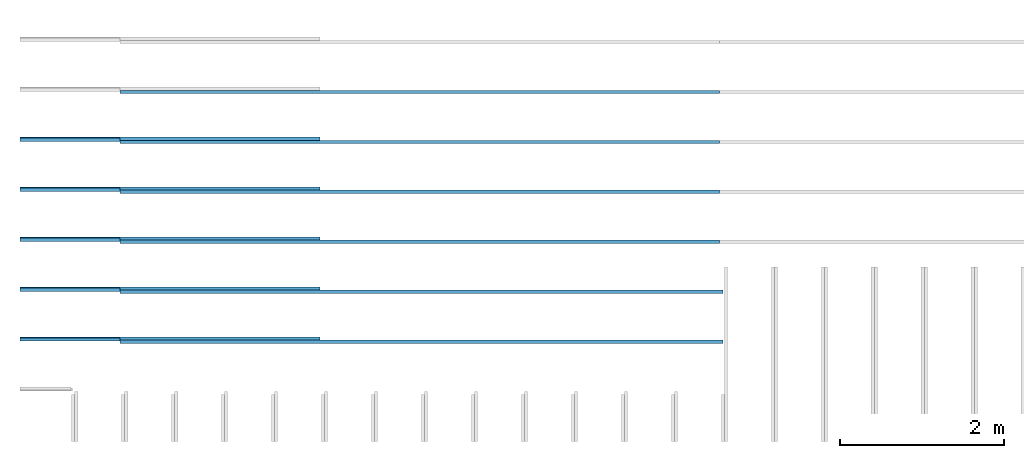
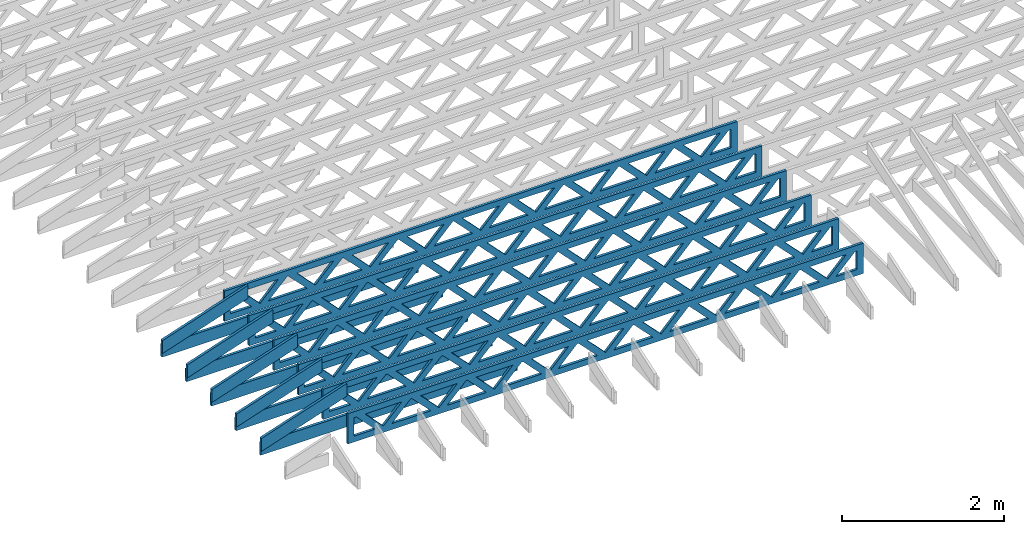
# One storey, part 1 of 18: 16 beams, 3 elements without a shape of their own.
"""IFC4 building model written with IfcOpenShell, lengths in feet."""

from ifc_helpers import new_model, entity, si_unit, converted_unit, derived_unit, direction, frame, frame_2d, origin, origin_2d_with_axis, place, context, subcontext, project, spatial, rectangle, extrude, clip, halfspace, source, transform, mapped, material, material_profile, profile_set, profile_usage, type_object, type_shapes, element, aggregate, save


model = new_model("IFC4")

# Units and contexts
model_context_1 = context("Model", 3, precision=0.0001, world=origin(), true_north=direction((6.12303176911189e-17, 1.0)))
model_context_2 = context("Model", 3, precision=0.0001, world=origin(), true_north=direction((6.12303176911189e-17, 1.0)))
body_context = subcontext(model_context_2, "Body", "Model", "MODEL_VIEW")
ifc_project = project(units=[converted_unit("LENGTHUNIT", "FOOT", entity("IfcRatioMeasure", 0.3048), si_unit("LENGTHUNIT", "METRE"), dimensions=[1, 0, 0, 0, 0, 0, 0]), converted_unit("AREAUNIT", "SQUARE FOOT", entity("IfcRatioMeasure", 0.09290304), si_unit("AREAUNIT", "SQUARE_METRE"), dimensions=[2, 0, 0, 0, 0, 0, 0]), converted_unit("VOLUMEUNIT", "CUBIC FOOT", entity("IfcRatioMeasure", 0.028316846592), si_unit("VOLUMEUNIT", "CUBIC_METRE"), dimensions=[3, 0, 0, 0, 0, 0, 0]), converted_unit("PLANEANGLEUNIT", "DEGREE", entity("IfcRatioMeasure", 0.0174532925199433), si_unit("PLANEANGLEUNIT", "RADIAN"), dimensions=[0, 0, 0, 0, 0, 0, 0]), si_unit("MASSUNIT", "GRAM", prefix="KILO"), derived_unit("MASSDENSITYUNIT", [(si_unit("MASSUNIT", "GRAM", prefix="KILO"), 1), (si_unit("LENGTHUNIT", "METRE"), -3)]), derived_unit("MOMENTOFINERTIAUNIT", [(si_unit("LENGTHUNIT", "METRE"), 4)]), si_unit("TIMEUNIT", "SECOND"), si_unit("FREQUENCYUNIT", "HERTZ"), si_unit("THERMODYNAMICTEMPERATUREUNIT", "DEGREE_CELSIUS"), derived_unit("THERMALTRANSMITTANCEUNIT", [(si_unit("MASSUNIT", "GRAM", prefix="KILO"), 1), (si_unit("THERMODYNAMICTEMPERATUREUNIT", "KELVIN"), -1), (si_unit("TIMEUNIT", "SECOND"), -3)]), derived_unit("VOLUMETRICFLOWRATEUNIT", [(si_unit("LENGTHUNIT", "METRE"), 3), (si_unit("TIMEUNIT", "SECOND"), -1)]), si_unit("ELECTRICCURRENTUNIT", "AMPERE"), si_unit("ELECTRICVOLTAGEUNIT", "VOLT"), si_unit("POWERUNIT", "WATT"), si_unit("FORCEUNIT", "NEWTON"), si_unit("ILLUMINANCEUNIT", "LUX"), si_unit("LUMINOUSFLUXUNIT", "LUMEN"), si_unit("LUMINOUSINTENSITYUNIT", "CANDELA"), derived_unit("USERDEFINED", [(si_unit("MASSUNIT", "GRAM", prefix="KILO"), -1), (si_unit("LENGTHUNIT", "METRE"), -2), (si_unit("TIMEUNIT", "SECOND"), 3), (si_unit("LUMINOUSFLUXUNIT", "LUMEN"), 1)]), derived_unit("LINEARVELOCITYUNIT", [(si_unit("LENGTHUNIT", "METRE"), 1), (si_unit("TIMEUNIT", "SECOND"), -1)]), si_unit("PRESSUREUNIT", "PASCAL"), derived_unit("USERDEFINED", [(si_unit("LENGTHUNIT", "METRE"), -2), (si_unit("MASSUNIT", "GRAM", prefix="KILO"), 1), (si_unit("TIMEUNIT", "SECOND"), -2)]), derived_unit("LINEARFORCEUNIT", [(si_unit("MASSUNIT", "GRAM", prefix="KILO"), 1), (si_unit("LENGTHUNIT", "METRE"), 1), (si_unit("TIMEUNIT", "SECOND"), -2), (si_unit("LENGTHUNIT", "METRE"), -1)]), derived_unit("PLANARFORCEUNIT", [(si_unit("MASSUNIT", "GRAM", prefix="KILO"), 1), (si_unit("LENGTHUNIT", "METRE"), 1), (si_unit("TIMEUNIT", "SECOND"), -2), (si_unit("LENGTHUNIT", "METRE"), -2)])], contexts=[model_context_1])

# Site, building, storey
site_placement = place(None, origin())
site = spatial("IfcSite", under=ifc_project, at=site_placement, CompositionType="ELEMENT")
building_placement = place(site_placement, origin())
building = spatial("IfcBuilding", under=site, at=building_placement, CompositionType="ELEMENT")
storey_placement = place(building_placement, frame((0.0, 0.0, 30.4375000000082)))
storey = spatial("IfcBuildingStorey", under=building, at=storey_placement, Name="ROOF", CompositionType="ELEMENT", Elevation=30.4375000000082)

# Assembly, beams
assembly_1_placement = place(storey_placement, origin())
assembly_1 = element("IfcElementAssembly", 1, at=assembly_1_placement, inside=storey, Name="Structural Beam System:Structural Framing System", ObjectType="Structural Beam System:Structural Framing System", AssemblyPlace="NOTDEFINED", PredefinedType="BEAM_GRID")
ifc_material_1 = material(Name="TOP CHORD OF FIELD FRAMED OVERHANG", Category="Materials")
ifc_material_profile_1 = material_profile(ifc_material_1, rectangle(XDim=0.604166666666667, YDim=0.125, at=origin_2d_with_axis()), Name="2X8 TOP CHORD")
ifc_profile_set_1 = profile_set([ifc_material_profile_1], Name="2X8 TOP CHORD")
ifc_profile_usage_1 = profile_usage(ifc_profile_set_1, cardinal=8)
beam_type_1 = type_object("IfcBeamType", Name="Dimension Lumber - Ends:2X8 TOP CHORD", PredefinedType="BEAM", material=ifc_profile_set_1)
shared_shape_1 = source(origin(), body_context, "Body", "Clipping", [
    clip(clip(extrude(rectangle(XDim=0.604166666666671, YDim=0.125, at=frame_2d((-1.83186799063151e-15, 0.0), x_axis=(1.0, 0.0))), frame((-2.10819527564865, 0.0, 0.0), z_axis=(1.0, 0.0, 0.0), x_axis=(0.0, 0.0, -1.0)), (0.0, 0.0, 1.0), 4.41772145980974), halfspace(frame((2.10819527564862, -0.0625000000000025, -0.302083333333339), z_axis=(0.948710608132914, 0.0, -0.316145823973807), x_axis=(0.0, 1.0, 0.0)), False)), halfspace(frame((-1.90686436713617, -0.0625000000000025, 0.302083333333328), z_axis=(-0.948710608132914, 0.0, 0.316145823973807), x_axis=(0.0, 1.0, 0.0)), False)),
])
type_shapes(beam_type_1, [shared_shape_1])
beam_1_placement = place(assembly_1_placement, frame((-267.833654839365, 933.945265019167, 1.93690371042361), z_axis=(-0.316227766016837, 0.0, 0.948683298050514), x_axis=(0.948683298050514, 0.0, 0.316227766016836)))
beam_1 = element("IfcBeam", 2, at=beam_1_placement, type_object=beam_type_1, material=ifc_profile_usage_1, Name="Dimension Lumber - Ends:2X8 TOP CHORD", ObjectType="Dimension Lumber - Ends:2X8 TOP CHORD", PredefinedType="BEAM", context=body_context, shape_type="MappedRepresentation", body=[
    mapped(shared_shape_1, transform((0.0, 0.0, 0.0), scale=1.0)),
])
ifc_profile_usage_2 = profile_usage(ifc_profile_set_1, cardinal=8)
beam_2_placement = place(assembly_1_placement, frame((-267.833654839365, 931.945265019167, 1.93690371042361), z_axis=(-0.316227766016837, 0.0, 0.948683298050514), x_axis=(0.948683298050514, 0.0, 0.316227766016836)))
beam_2 = element("IfcBeam", 3, at=beam_2_placement, type_object=beam_type_1, material=ifc_profile_usage_2, Name="Dimension Lumber - Ends:2X8 TOP CHORD", ObjectType="Dimension Lumber - Ends:2X8 TOP CHORD", PredefinedType="BEAM", context=body_context, shape_type="MappedRepresentation", body=[
    mapped(shared_shape_1, transform((0.0, 0.0, 0.0), scale=1.0)),
])
ifc_profile_usage_3 = profile_usage(ifc_profile_set_1, cardinal=8)
beam_3_placement = place(assembly_1_placement, frame((-267.833654839365, 929.945265019167, 1.93690371042361), z_axis=(-0.316227766016837, 0.0, 0.948683298050514), x_axis=(0.948683298050514, 0.0, 0.316227766016836)))
beam_3 = element("IfcBeam", 4, at=beam_3_placement, type_object=beam_type_1, material=ifc_profile_usage_3, Name="Dimension Lumber - Ends:2X8 TOP CHORD", ObjectType="Dimension Lumber - Ends:2X8 TOP CHORD", PredefinedType="BEAM", context=body_context, shape_type="MappedRepresentation", body=[
    mapped(shared_shape_1, transform((0.0, 0.0, 0.0), scale=1.0)),
])
ifc_profile_usage_4 = profile_usage(ifc_profile_set_1, cardinal=8)
beam_4_placement = place(assembly_1_placement, frame((-267.833654839365, 927.945265019167, 1.93690371042361), z_axis=(-0.316227766016837, 0.0, 0.948683298050514), x_axis=(0.948683298050514, 0.0, 0.316227766016836)))
beam_4 = element("IfcBeam", 5, at=beam_4_placement, type_object=beam_type_1, material=ifc_profile_usage_4, Name="Dimension Lumber - Ends:2X8 TOP CHORD", ObjectType="Dimension Lumber - Ends:2X8 TOP CHORD", PredefinedType="BEAM", context=body_context, shape_type="MappedRepresentation", body=[
    mapped(shared_shape_1, transform((0.0, 0.0, 0.0), scale=1.0)),
])
ifc_profile_usage_5 = profile_usage(ifc_profile_set_1, cardinal=8)
beam_5_placement = place(assembly_1_placement, frame((-267.833654839365, 925.945265019167, 1.93690371042361), z_axis=(-0.316227766016837, 0.0, 0.948683298050514), x_axis=(0.948683298050514, 0.0, 0.316227766016836)))
beam_5 = element("IfcBeam", 6, at=beam_5_placement, type_object=beam_type_1, material=ifc_profile_usage_5, Name="Dimension Lumber - Ends:2X8 TOP CHORD", ObjectType="Dimension Lumber - Ends:2X8 TOP CHORD", PredefinedType="BEAM", context=body_context, shape_type="MappedRepresentation", body=[
    mapped(shared_shape_1, transform((0.0, 0.0, 0.0), scale=1.0)),
])
aggregate(assembly_1, [beam_1, beam_2, beam_3, beam_4, beam_5])

assembly_2_placement = place(storey_placement, origin())
assembly_2 = element("IfcElementAssembly", 7, at=assembly_2_placement, inside=storey, Name="Structural Beam System:Structural Framing System", ObjectType="Structural Beam System:Structural Framing System", AssemblyPlace="NOTDEFINED", PredefinedType="BEAM_GRID")
ifc_material_2 = material(Name="2X8 TO ROOF", Category="Materials")
ifc_material_profile_2 = material_profile(ifc_material_2, rectangle(XDim=0.604166666666667, YDim=0.125000000000011, at=origin_2d_with_axis()), Name="2X8")
ifc_profile_set_2 = profile_set([ifc_material_profile_2], Name="2X8")
ifc_profile_usage_6 = profile_usage(ifc_profile_set_2, cardinal=8)
beam_type_2 = type_object("IfcBeamType", Name="061100 - Wood Framing:2X8", PredefinedType="BEAM", material=ifc_profile_set_2)
shared_shape_2 = source(origin(), body_context, "Body", "SweptSolid", [
    extrude(rectangle(XDim=0.604166666666667, YDim=0.125000000000011, at=origin_2d_with_axis()), frame((-6.0, 0.0, 0.0), z_axis=(1.0, 0.0, 0.0), x_axis=(0.0, 0.0, -1.0)), (0.0, 0.0, 1.0), 12.000000000033),
])
type_shapes(beam_type_2, [shared_shape_2])
beam_6_placement = place(assembly_2_placement, frame((-263.738238667831, 929.986939926744, 1.07291666665848), z_axis=(0.0, 0.0, 1.0), x_axis=(-1.0, 0.0, 0.0)))
beam_6 = element("IfcBeam", 8, at=beam_6_placement, type_object=beam_type_2, material=ifc_profile_usage_6, Name="061100 - Wood Framing:2X8", ObjectType="061100 - Wood Framing:2X8", PredefinedType="BEAM", context=body_context, shape_type="MappedRepresentation", body=[
    mapped(shared_shape_2, transform((0.0, 0.0, 0.0), scale=1.0)),
])
ifc_profile_usage_7 = profile_usage(ifc_profile_set_2, cardinal=8)
beam_7_placement = place(assembly_2_placement, frame((-263.738253742943, 927.98693992663, 1.07291666665848), z_axis=(0.0, 0.0, 1.0), x_axis=(-1.0, 0.0, 0.0)))
beam_7 = element("IfcBeam", 9, at=beam_7_placement, type_object=beam_type_2, material=ifc_profile_usage_7, Name="061100 - Wood Framing:2X8", ObjectType="061100 - Wood Framing:2X8", PredefinedType="BEAM", context=body_context, shape_type="MappedRepresentation", body=[
    mapped(shared_shape_2, transform((0.0, 0.0, 0.0), scale=1.0)),
])
ifc_profile_usage_8 = profile_usage(ifc_profile_set_2, cardinal=8)
beam_8_placement = place(assembly_2_placement, frame((-263.738268818055, 925.986939926517, 1.07291666665849), z_axis=(0.0, 0.0, 1.0), x_axis=(-1.0, 0.0, 0.0)))
beam_8 = element("IfcBeam", 10, at=beam_8_placement, type_object=beam_type_2, material=ifc_profile_usage_8, Name="061100 - Wood Framing:2X8", ObjectType="061100 - Wood Framing:2X8", PredefinedType="BEAM", context=body_context, shape_type="MappedRepresentation", body=[
    mapped(shared_shape_2, transform((0.0, 0.0, 0.0), scale=1.0)),
])
ifc_profile_usage_9 = profile_usage(ifc_profile_set_2, cardinal=8)
beam_9_placement = place(assembly_2_placement, frame((-263.738208517606, 933.986939926972, 1.07291666665846), z_axis=(0.0, 0.0, 1.0), x_axis=(-1.0, 0.0, 0.0)))
beam_9 = element("IfcBeam", 11, at=beam_9_placement, type_object=beam_type_2, material=ifc_profile_usage_9, Name="061100 - Wood Framing:2X8", ObjectType="061100 - Wood Framing:2X8", PredefinedType="BEAM", context=body_context, shape_type="MappedRepresentation", body=[
    mapped(shared_shape_2, transform((0.0, 0.0, 0.0), scale=1.0)),
])
ifc_profile_usage_10 = profile_usage(ifc_profile_set_2, cardinal=8)
beam_10_placement = place(assembly_2_placement, frame((-263.738223592719, 931.986939926858, 1.07291666665847), z_axis=(0.0, 0.0, 1.0), x_axis=(-1.0, 0.0, 0.0)))
beam_10 = element("IfcBeam", 12, at=beam_10_placement, type_object=beam_type_2, material=ifc_profile_usage_10, Name="061100 - Wood Framing:2X8", ObjectType="061100 - Wood Framing:2X8", PredefinedType="BEAM", context=body_context, shape_type="MappedRepresentation", body=[
    mapped(shared_shape_2, transform((0.0, 0.0, 0.0), scale=1.0)),
])
aggregate(assembly_2, [beam_6, beam_7, beam_8, beam_9, beam_10])

assembly_3_placement = place(storey_placement, origin())
assembly_3 = element("IfcElementAssembly", 13, at=assembly_3_placement, inside=storey, Name="Structural Beam System:Structural Framing System", ObjectType="Structural Beam System:Structural Framing System", AssemblyPlace="NOTDEFINED", PredefinedType="BEAM_GRID")
ifc_material_3 = material(Name="WOOD TRUSS", Category="Materials")
ifc_material_profile_3 = material_profile(ifc_material_3, rectangle(XDim=1.73473973950632, YDim=0.125, at=origin_2d_with_axis()))
ifc_material_profile_4 = material_profile(ifc_material_3, rectangle(XDim=1.73473973950633, YDim=0.125, at=frame_2d((-1.11022302462516e-16, 0.0), x_axis=(1.0, 0.0))))
ifc_material_profile_5 = material_profile(ifc_material_3, rectangle(XDim=1.73473973950632, YDim=0.125, at=origin_2d_with_axis()))
ifc_material_profile_6 = material_profile(ifc_material_3, rectangle(XDim=1.73473973950633, YDim=0.125, at=origin_2d_with_axis()))
ifc_material_profile_7 = material_profile(ifc_material_3, rectangle(XDim=1.73473973950632, YDim=0.125, at=frame_2d((-5.55111512312578e-17, 0.0), x_axis=(1.0, 0.0))))
ifc_material_profile_8 = material_profile(ifc_material_3, rectangle(XDim=1.73473973950633, YDim=0.125, at=frame_2d((-2.77555756156289e-16, 0.0), x_axis=(1.0, 0.0))))
ifc_material_profile_9 = material_profile(ifc_material_3, rectangle(XDim=1.73473973950632, YDim=0.125, at=frame_2d((-4.9960036108132e-16, 0.0), x_axis=(1.0, 0.0))))
ifc_material_profile_10 = material_profile(ifc_material_3, rectangle(XDim=1.73473973950633, YDim=0.125, at=frame_2d((4.44089209850063e-16, 0.0), x_axis=(1.0, 0.0))))
ifc_material_profile_11 = material_profile(ifc_material_3, rectangle(XDim=1.73473973950632, YDim=0.125, at=origin_2d_with_axis()))
ifc_material_profile_12 = material_profile(ifc_material_3, rectangle(XDim=1.73473973950633, YDim=0.125, at=frame_2d((-4.9960036108132e-16, 0.0), x_axis=(1.0, 0.0))))
ifc_material_profile_13 = material_profile(ifc_material_3, rectangle(XDim=0.291666666666664, YDim=0.125, at=frame_2d((-2.77555756156289e-17, 0.0), x_axis=(1.0, 0.0))))
ifc_material_profile_14 = material_profile(ifc_material_3, rectangle(XDim=0.291666666666628, YDim=0.124999999999995, at=frame_2d((-5.55111512312578e-17, 0.0), x_axis=(1.0, 0.0))))
ifc_material_profile_15 = material_profile(ifc_material_3, rectangle(XDim=0.916666666666666, YDim=0.125000000000003, at=frame_2d((-2.77555756156289e-17, 0.0), x_axis=(1.0, 0.0))))
ifc_material_profile_16 = material_profile(ifc_material_3, rectangle(XDim=0.916666666666651, YDim=0.125, at=frame_2d((-2.77555756156289e-17, 0.0), x_axis=(1.0, 0.0))))
ifc_profile_set_3 = profile_set([ifc_material_profile_3, ifc_material_profile_4, ifc_material_profile_5, ifc_material_profile_6, ifc_material_profile_7, ifc_material_profile_8, ifc_material_profile_9, ifc_material_profile_10, ifc_material_profile_11, ifc_material_profile_12, ifc_material_profile_13, ifc_material_profile_14, ifc_material_profile_15, ifc_material_profile_16])
ifc_profile_usage_11 = profile_usage(ifc_profile_set_3, cardinal=8)
beam_type_3 = type_object("IfcBeamType", PredefinedType="BEAM", material=ifc_profile_set_3)
shared_shape_3 = source(origin(), body_context, "Body", "SweptSolid", [
    extrude(rectangle(XDim=1.73473973950632, YDim=0.125, at=frame_2d((8.88178419700125e-16, 0.0), x_axis=(1.0, 0.0))), frame((8.31693784968716, 0.0, 0.101118361020562), z_axis=(0.720569184836762, 0.0, -0.693383046997606), x_axis=(0.693383046997606, 0.0, 0.720569184836762)), (0.0, 0.0, 1.0), 0.291666666666667),
    extrude(rectangle(XDim=1.73473973950633, YDim=0.125, at=frame_2d((4.9960036108132e-16, 0.0), x_axis=(1.0, 0.0))), frame((7.06665197601389, 0.0, -0.101118361020407), z_axis=(0.720569184836758, 0.0, 0.69338304699761), x_axis=(0.69338304699761, 0.0, -0.720569184836758)), (0.0, 0.0, 1.0), 0.291666666666667),
    extrude(rectangle(XDim=1.73473973950632, YDim=0.125, at=origin_2d_with_axis()), frame((5.71797854336309, 0.0, 0.101118361020562), z_axis=(0.720569184836762, 0.0, -0.693383046997606), x_axis=(0.693383046997606, 0.0, 0.720569184836762)), (0.0, 0.0, 1.0), 0.291666666666667),
    extrude(rectangle(XDim=1.73473973950633, YDim=0.125, at=frame_2d((-4.9960036108132e-16, 0.0), x_axis=(1.0, 0.0))), frame((4.46769266968982, 0.0, -0.101118361020407), z_axis=(0.720569184836758, 0.0, 0.69338304699761), x_axis=(0.69338304699761, 0.0, -0.720569184836758)), (0.0, 0.0, 1.0), 0.291666666666667),
    extrude(rectangle(XDim=1.73473973950632, YDim=0.125, at=frame_2d((3.33066907387547e-16, 0.0), x_axis=(1.0, 0.0))), frame((3.11901923703901, 0.0, 0.101118361020562), z_axis=(0.720569184836762, 0.0, -0.693383046997606), x_axis=(0.693383046997606, 0.0, 0.720569184836762)), (0.0, 0.0, 1.0), 0.291666666666667),
    extrude(rectangle(XDim=1.73473973950633, YDim=0.125, at=frame_2d((-1.11022302462516e-16, 0.0), x_axis=(1.0, 0.0))), frame((1.86873336336574, 0.0, -0.101118361020407), z_axis=(0.720569184836758, 0.0, 0.69338304699761), x_axis=(0.69338304699761, 0.0, -0.720569184836758)), (0.0, 0.0, 1.0), 0.291666666666666),
    extrude(rectangle(XDim=1.73473973950632, YDim=0.125, at=frame_2d((5.55111512312578e-17, 0.0), x_axis=(1.0, 0.0))), frame((0.520059930714937, 0.0, 0.101118361020562), z_axis=(0.720569184836762, 0.0, -0.693383046997606), x_axis=(0.693383046997606, 0.0, 0.720569184836762)), (0.0, 0.0, 1.0), 0.291666666666667),
    extrude(rectangle(XDim=1.73473973950633, YDim=0.125, at=origin_2d_with_axis()), frame((-0.730225942958334, 0.0, -0.101118361020407), z_axis=(0.720569184836758, 0.0, 0.69338304699761), x_axis=(0.69338304699761, 0.0, -0.720569184836758)), (0.0, 0.0, 1.0), 0.291666666666666),
    extrude(rectangle(XDim=1.73473973950632, YDim=0.125, at=frame_2d((-5.55111512312578e-17, 0.0), x_axis=(1.0, 0.0))), frame((-2.07889937560914, 0.0, 0.101118361020562), z_axis=(0.720569184836762, 0.0, -0.693383046997606), x_axis=(0.693383046997606, 0.0, 0.720569184836762)), (0.0, 0.0, 1.0), 0.291666666666667),
    extrude(rectangle(XDim=1.73473973950633, YDim=0.125, at=frame_2d((-2.77555756156289e-16, 0.0), x_axis=(1.0, 0.0))), frame((-3.32918524928241, 0.0, -0.101118361020407), z_axis=(0.720569184836758, 0.0, 0.69338304699761), x_axis=(0.69338304699761, 0.0, -0.720569184836758)), (0.0, 0.0, 1.0), 0.291666666666666),
    extrude(rectangle(XDim=1.73473973950632, YDim=0.125, at=origin_2d_with_axis()), frame((-4.67785868193321, 0.0, 0.101118361020562), z_axis=(0.720569184836762, 0.0, -0.693383046997606), x_axis=(0.693383046997606, 0.0, 0.720569184836762)), (0.0, 0.0, 1.0), 0.291666666666667),
    extrude(rectangle(XDim=1.73473973950633, YDim=0.125, at=frame_2d((-4.9960036108132e-16, 0.0), x_axis=(1.0, 0.0))), frame((-5.92814455560648, 0.0, -0.101118361020407), z_axis=(0.720569184836758, 0.0, 0.69338304699761), x_axis=(0.69338304699761, 0.0, -0.720569184836758)), (0.0, 0.0, 1.0), 0.291666666666667),
    extrude(rectangle(XDim=1.73473973950632, YDim=0.125, at=frame_2d((-5.55111512312578e-16, 0.0), x_axis=(1.0, 0.0))), frame((-7.27681798825729, 0.0, 0.101118361020562), z_axis=(0.720569184836762, 0.0, -0.693383046997606), x_axis=(0.693383046997606, 0.0, 0.720569184836762)), (0.0, 0.0, 1.0), 0.291666666666667),
    extrude(rectangle(XDim=1.73473973950633, YDim=0.125, at=origin_2d_with_axis()), frame((-8.52710386193056, 0.0, -0.101118361020407), z_axis=(0.720569184836758, 0.0, 0.69338304699761), x_axis=(0.69338304699761, 0.0, -0.720569184836758)), (0.0, 0.0, 1.0), 0.291666666666666),
    extrude(rectangle(XDim=1.73473973950632, YDim=0.125, at=frame_2d((-1.0547118733939e-15, 0.0), x_axis=(1.0, 0.0))), frame((10.9158971560112, 0.0, 0.101118361020503), z_axis=(0.720569184836762, 0.0, -0.693383046997606), x_axis=(0.693383046997606, 0.0, 0.720569184836762)), (0.0, 0.0, 1.0), 0.291666666666664),
    extrude(rectangle(XDim=1.73473973950633, YDim=0.125, at=origin_2d_with_axis()), frame((9.66561128233796, 0.0, -0.101118361020466), z_axis=(0.720569184836758, 0.0, 0.69338304699761), x_axis=(0.69338304699761, 0.0, -0.720569184836758)), (0.0, 0.0, 1.0), 0.291666666666666),
    extrude(rectangle(XDim=1.73473973950632, YDim=0.125, at=frame_2d((9.43689570931383e-16, 0.0), x_axis=(1.0, 0.0))), frame((-9.87577729458136, 0.0, 0.101118361020564), z_axis=(0.720569184836762, 0.0, -0.693383046997606), x_axis=(0.693383046997606, 0.0, 0.720569184836762)), (0.0, 0.0, 1.0), 0.291666666666667),
    extrude(rectangle(XDim=1.73473973950633, YDim=0.125, at=origin_2d_with_axis()), frame((-11.1260631682546, 0.0, -0.101118361020405), z_axis=(0.720569184836758, 0.0, 0.69338304699761), x_axis=(0.69338304699761, 0.0, -0.720569184836758)), (0.0, 0.0, 1.0), 0.291666666666666),
    extrude(rectangle(XDim=0.291666666666664, YDim=0.125, at=frame_2d((-2.77555756156289e-17, 0.0), x_axis=(1.0, 0.0))), frame((-12.0625038919629, 0.0, 0.604166666666611), z_axis=(1.0, 0.0, 0.0), x_axis=(0.0, 0.0, -1.0)), (0.0, 0.0, 1.0), 24.1250077839258),
    extrude(rectangle(XDim=0.291666666666628, YDim=0.124999999999995, at=frame_2d((-5.55111512312578e-17, 0.0), x_axis=(1.0, 0.0))), frame((-12.0625038919627, 0.0, -0.604166666666693), z_axis=(1.0, 0.0, 0.0), x_axis=(0.0, 0.0, -1.0)), (0.0, 0.0, 1.0), 24.1250077839255),
    extrude(rectangle(XDim=0.916666666666666, YDim=0.125000000000003, at=frame_2d((-2.77555756156289e-17, 0.0), x_axis=(1.0, 0.0))), frame((11.7708372252962, 0.0, 0.0), z_axis=(1.0, 0.0, 0.0), x_axis=(0.0, 0.0, -1.0)), (0.0, 0.0, 1.0), 0.291666666666687),
    extrude(rectangle(XDim=0.916666666666651, YDim=0.125, at=frame_2d((-2.77555756156289e-17, -6.93889390390723e-18), x_axis=(1.0, 0.0))), frame((-12.0625038919629, 0.0, 0.0), z_axis=(1.0, 0.0, 0.0), x_axis=(0.0, 0.0, -1.0)), (0.0, 0.0, 1.0), 0.291666666666687),
])
type_shapes(beam_type_3, [shared_shape_3])
beam_11_placement = place(assembly_3_placement, frame((-253.675664377424, 925.861934882651, 0.749999999991701)))
beam_11 = element("IfcBeam", 14, at=beam_11_placement, type_object=beam_type_3, material=ifc_profile_usage_11, PredefinedType="BEAM", context=body_context, shape_type="MappedRepresentation", body=[
    mapped(shared_shape_3, transform((0.0, 0.0, 0.0), scale=1.0)),
])
ifc_profile_usage_12 = profile_usage(ifc_profile_set_3, cardinal=8)
beam_12_placement = place(assembly_3_placement, frame((-253.675664377424, 927.861934882651, 0.749999999991697)))
beam_12 = element("IfcBeam", 15, at=beam_12_placement, type_object=beam_type_3, material=ifc_profile_usage_12, PredefinedType="BEAM", context=body_context, shape_type="MappedRepresentation", body=[
    mapped(shared_shape_3, transform((0.0, 0.0, 0.0), scale=1.0)),
])
ifc_profile_usage_13 = profile_usage(ifc_profile_set_3, cardinal=8)
beam_type_4 = type_object("IfcBeamType", PredefinedType="BEAM", material=ifc_profile_set_3)
shared_shape_4 = source(origin(), body_context, "Body", "SweptSolid", [
    extrude(rectangle(XDim=1.73473973950632, YDim=0.125, at=frame_2d((8.88178419700125e-16, 0.0), x_axis=(1.0, 0.0))), frame((8.27006284966195, 0.0, 0.101118361020562), z_axis=(0.720569184836762, 0.0, -0.693383046997606), x_axis=(0.693383046997606, 0.0, 0.720569184836762)), (0.0, 0.0, 1.0), 0.291666666666667),
    extrude(rectangle(XDim=1.73473973950633, YDim=0.125, at=frame_2d((4.9960036108132e-16, 0.0), x_axis=(1.0, 0.0))), frame((7.01977697598868, 0.0, -0.101118361020407), z_axis=(0.720569184836758, 0.0, 0.69338304699761), x_axis=(0.69338304699761, 0.0, -0.720569184836758)), (0.0, 0.0, 1.0), 0.291666666666667),
    extrude(rectangle(XDim=1.73473973950632, YDim=0.125, at=origin_2d_with_axis()), frame((5.68672854334628, 0.0, 0.101118361020562), z_axis=(0.720569184836762, 0.0, -0.693383046997606), x_axis=(0.693383046997606, 0.0, 0.720569184836762)), (0.0, 0.0, 1.0), 0.291666666666667),
    extrude(rectangle(XDim=1.73473973950633, YDim=0.125, at=frame_2d((-4.9960036108132e-16, 0.0), x_axis=(1.0, 0.0))), frame((4.43644266967301, 0.0, -0.101118361020407), z_axis=(0.720569184836758, 0.0, 0.69338304699761), x_axis=(0.69338304699761, 0.0, -0.720569184836758)), (0.0, 0.0, 1.0), 0.291666666666667),
    extrude(rectangle(XDim=1.73473973950632, YDim=0.125, at=frame_2d((3.33066907387547e-16, 0.0), x_axis=(1.0, 0.0))), frame((3.10339423703061, 0.0, 0.101118361020562), z_axis=(0.720569184836762, 0.0, -0.693383046997606), x_axis=(0.693383046997606, 0.0, 0.720569184836762)), (0.0, 0.0, 1.0), 0.291666666666667),
    extrude(rectangle(XDim=1.73473973950633, YDim=0.125, at=frame_2d((-1.11022302462516e-16, 0.0), x_axis=(1.0, 0.0))), frame((1.85310836335734, 0.0, -0.101118361020407), z_axis=(0.720569184836758, 0.0, 0.69338304699761), x_axis=(0.69338304699761, 0.0, -0.720569184836758)), (0.0, 0.0, 1.0), 0.291666666666666),
    extrude(rectangle(XDim=1.73473973950632, YDim=0.125, at=frame_2d((5.55111512312578e-17, 0.0), x_axis=(1.0, 0.0))), frame((0.520059930714937, 0.0, 0.101118361020562), z_axis=(0.720569184836762, 0.0, -0.693383046997606), x_axis=(0.693383046997606, 0.0, 0.720569184836762)), (0.0, 0.0, 1.0), 0.291666666666667),
    extrude(rectangle(XDim=1.73473973950633, YDim=0.125, at=origin_2d_with_axis()), frame((-0.730225942958334, 0.0, -0.101118361020407), z_axis=(0.720569184836758, 0.0, 0.69338304699761), x_axis=(0.69338304699761, 0.0, -0.720569184836758)), (0.0, 0.0, 1.0), 0.291666666666666),
    extrude(rectangle(XDim=1.73473973950632, YDim=0.125, at=frame_2d((-5.55111512312578e-17, 0.0), x_axis=(1.0, 0.0))), frame((-2.06327437560074, 0.0, 0.101118361020562), z_axis=(0.720569184836762, 0.0, -0.693383046997606), x_axis=(0.693383046997606, 0.0, 0.720569184836762)), (0.0, 0.0, 1.0), 0.291666666666667),
    extrude(rectangle(XDim=1.73473973950633, YDim=0.125, at=frame_2d((-2.77555756156289e-16, 0.0), x_axis=(1.0, 0.0))), frame((-3.31356024927401, 0.0, -0.101118361020407), z_axis=(0.720569184836758, 0.0, 0.69338304699761), x_axis=(0.69338304699761, 0.0, -0.720569184836758)), (0.0, 0.0, 1.0), 0.291666666666666),
    extrude(rectangle(XDim=1.73473973950632, YDim=0.125, at=origin_2d_with_axis()), frame((-4.64660868191641, 0.0, 0.101118361020562), z_axis=(0.720569184836762, 0.0, -0.693383046997606), x_axis=(0.693383046997606, 0.0, 0.720569184836762)), (0.0, 0.0, 1.0), 0.291666666666667),
    extrude(rectangle(XDim=1.73473973950633, YDim=0.125, at=frame_2d((-4.9960036108132e-16, 0.0), x_axis=(1.0, 0.0))), frame((-5.89689455558968, 0.0, -0.101118361020407), z_axis=(0.720569184836758, 0.0, 0.69338304699761), x_axis=(0.69338304699761, 0.0, -0.720569184836758)), (0.0, 0.0, 1.0), 0.291666666666667),
    extrude(rectangle(XDim=1.73473973950632, YDim=0.125, at=frame_2d((5.55111512312578e-16, 0.0), x_axis=(1.0, 0.0))), frame((-7.22994298823208, 0.0, 0.101118361020562), z_axis=(0.720569184836762, 0.0, -0.693383046997606), x_axis=(0.693383046997606, 0.0, 0.720569184836762)), (0.0, 0.0, 1.0), 0.291666666666667),
    extrude(rectangle(XDim=1.73473973950633, YDim=0.125, at=origin_2d_with_axis()), frame((-8.48022886190535, 0.0, -0.101118361020407), z_axis=(0.720569184836758, 0.0, 0.69338304699761), x_axis=(0.69338304699761, 0.0, -0.720569184836758)), (0.0, 0.0, 1.0), 0.291666666666666),
    extrude(rectangle(XDim=1.73473973950632, YDim=0.125, at=frame_2d((-8.88178419700125e-16, 0.0), x_axis=(1.0, 0.0))), frame((10.8533971559776, 0.0, 0.101118361020503), z_axis=(0.720569184836762, 0.0, -0.693383046997606), x_axis=(0.693383046997606, 0.0, 0.720569184836762)), (0.0, 0.0, 1.0), 0.291666666666664),
    extrude(rectangle(XDim=1.73473973950633, YDim=0.125, at=origin_2d_with_axis()), frame((9.60311128230435, 0.0, -0.101118361020466), z_axis=(0.720569184836758, 0.0, 0.69338304699761), x_axis=(0.69338304699761, 0.0, -0.720569184836758)), (0.0, 0.0, 1.0), 0.291666666666666),
    extrude(rectangle(XDim=1.73473973950632, YDim=0.125, at=frame_2d((8.88178419700125e-16, 0.0), x_axis=(1.0, 0.0))), frame((-9.81327729454775, 0.0, 0.101118361020564), z_axis=(0.720569184836762, 0.0, -0.693383046997606), x_axis=(0.693383046997606, 0.0, 0.720569184836762)), (0.0, 0.0, 1.0), 0.291666666666667),
    extrude(rectangle(XDim=1.73473973950633, YDim=0.125, at=origin_2d_with_axis()), frame((-11.063563168221, 0.0, -0.101118361020405), z_axis=(0.720569184836758, 0.0, 0.69338304699761), x_axis=(0.69338304699761, 0.0, -0.720569184836758)), (0.0, 0.0, 1.0), 0.291666666666666),
    extrude(rectangle(XDim=0.291666666666664, YDim=0.125, at=frame_2d((-2.77555756156289e-17, 0.0), x_axis=(1.0, 0.0))), frame((-12.0000038919293, 0.0, 0.604166666666611), z_axis=(1.0, 0.0, 0.0), x_axis=(0.0, 0.0, -1.0)), (0.0, 0.0, 1.0), 24.0000077838585),
    extrude(rectangle(XDim=0.291666666666628, YDim=0.124999999999995, at=frame_2d((-5.55111512312578e-17, 0.0), x_axis=(1.0, 0.0))), frame((-12.0000038919291, 0.0, -0.604166666666693), z_axis=(1.0, 0.0, 0.0), x_axis=(0.0, 0.0, -1.0)), (0.0, 0.0, 1.0), 24.0000077838583),
    extrude(rectangle(XDim=0.916666666666666, YDim=0.125000000000003, at=frame_2d((-2.77555756156289e-17, 0.0), x_axis=(1.0, 0.0))), frame((11.7083372252626, 0.0, 0.0), z_axis=(1.0, 0.0, 0.0), x_axis=(0.0, 0.0, -1.0)), (0.0, 0.0, 1.0), 0.291666666666687),
    extrude(rectangle(XDim=0.916666666666651, YDim=0.125, at=frame_2d((-2.77555756156289e-17, 0.0), x_axis=(1.0, 0.0))), frame((-12.0000038919293, 0.0, 0.0), z_axis=(1.0, 0.0, 0.0), x_axis=(0.0, 0.0, -1.0)), (0.0, 0.0, 1.0), 0.291666666666687),
])
type_shapes(beam_type_4, [shared_shape_4])
beam_13_placement = place(assembly_3_placement, frame((-253.738164377457, 929.861934882651, 0.74999999999169)))
beam_13 = element("IfcBeam", 16, at=beam_13_placement, type_object=beam_type_4, material=ifc_profile_usage_13, PredefinedType="BEAM", context=body_context, shape_type="MappedRepresentation", body=[
    mapped(shared_shape_4, transform((0.0, 0.0, 0.0), scale=1.0)),
])
ifc_profile_usage_14 = profile_usage(ifc_profile_set_3, cardinal=8)
beam_14_placement = place(assembly_3_placement, frame((-253.738164377457, 931.861934882651, 0.749999999991687)))
beam_14 = element("IfcBeam", 17, at=beam_14_placement, type_object=beam_type_4, material=ifc_profile_usage_14, PredefinedType="BEAM", context=body_context, shape_type="MappedRepresentation", body=[
    mapped(shared_shape_4, transform((0.0, 0.0, 0.0), scale=1.0)),
])
ifc_profile_usage_15 = profile_usage(ifc_profile_set_3, cardinal=8)
beam_15_placement = place(assembly_3_placement, frame((-253.738164377457, 935.861934882651, 0.749999999991672)))
beam_15 = element("IfcBeam", 18, at=beam_15_placement, type_object=beam_type_4, material=ifc_profile_usage_15, PredefinedType="BEAM", context=body_context, shape_type="MappedRepresentation", body=[
    mapped(shared_shape_4, transform((0.0, 0.0, 0.0), scale=1.0)),
])
ifc_profile_usage_16 = profile_usage(ifc_profile_set_3, cardinal=8)
beam_16_placement = place(assembly_3_placement, frame((-253.738164377457, 933.861934882651, 0.74999999999168)))
beam_16 = element("IfcBeam", 19, at=beam_16_placement, type_object=beam_type_4, material=ifc_profile_usage_16, PredefinedType="BEAM", context=body_context, shape_type="MappedRepresentation", body=[
    mapped(shared_shape_4, transform((0.0, 0.0, 0.0), scale=1.0)),
])
aggregate(assembly_3, [beam_11, beam_12, beam_13, beam_14, beam_15, beam_16])

save(model, "model.ifc")
